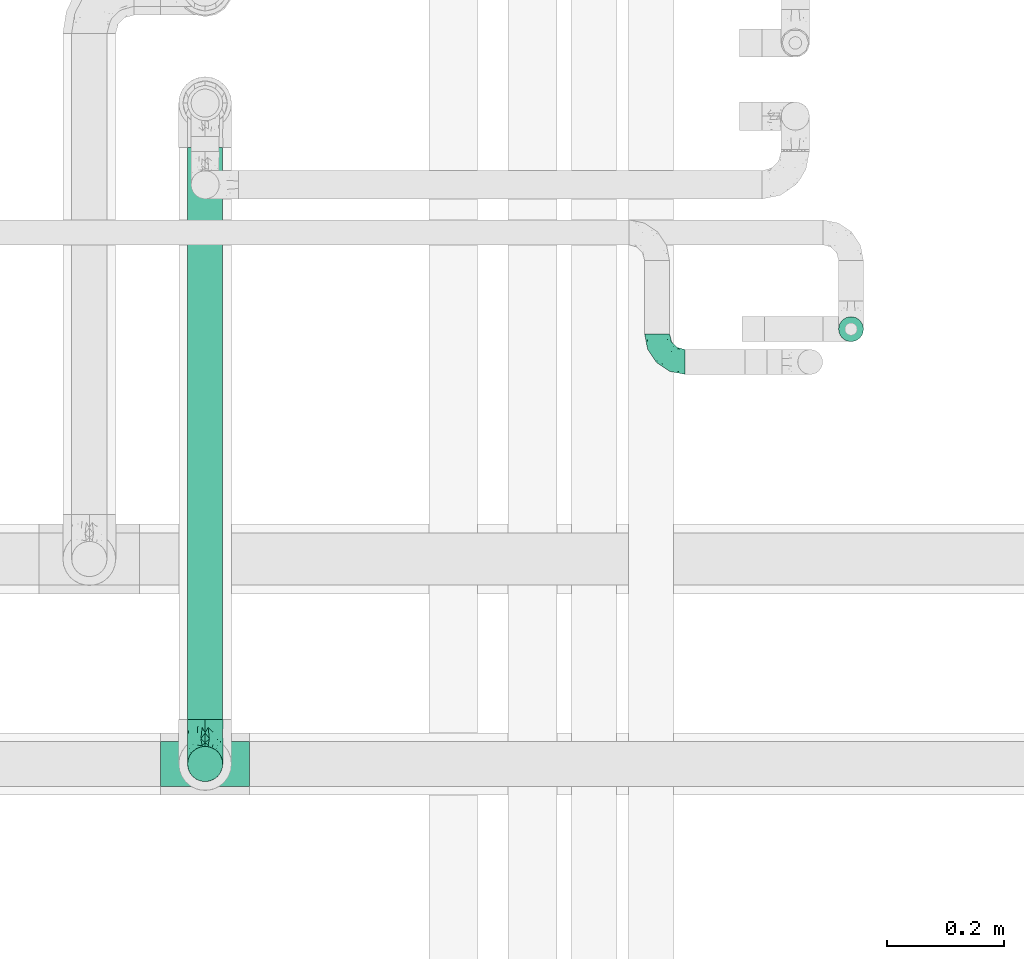
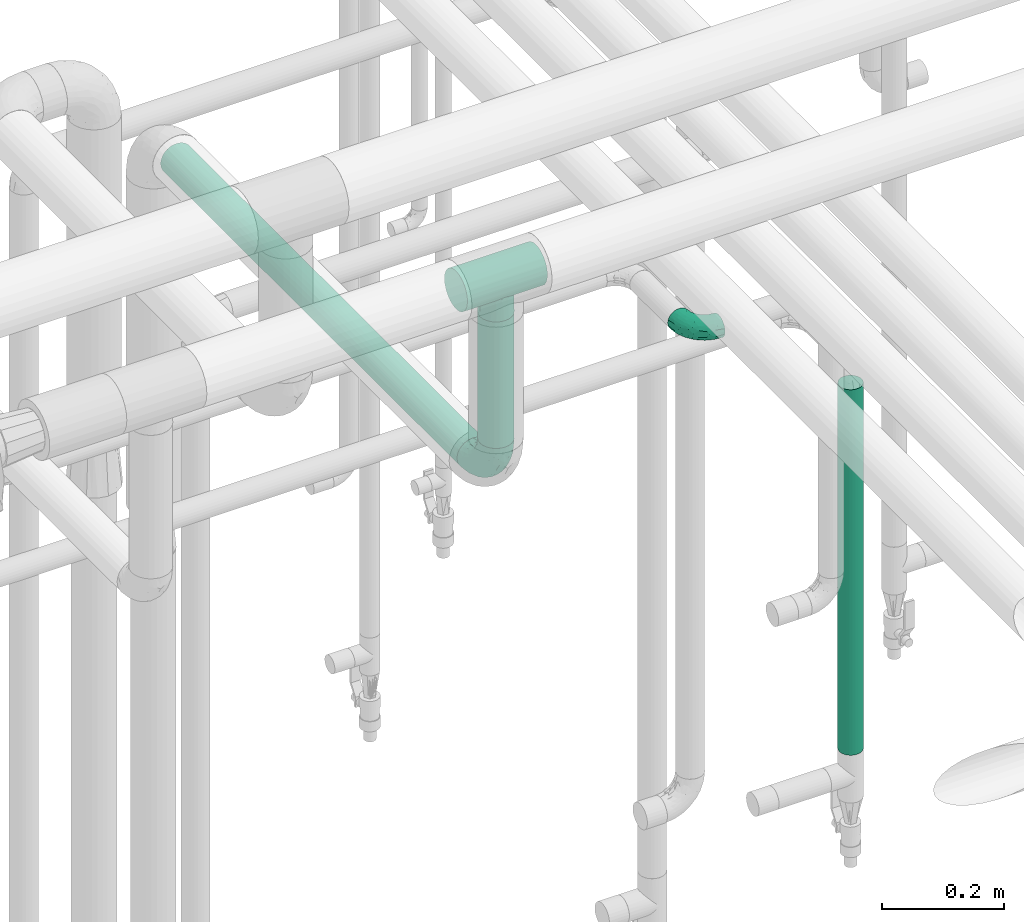
# One storey, part 574 of 827: 3 flow fittings, 3 flow segments.
"""IFC2X3 building model written with IfcOpenShell, lengths in millimetres."""

from ifc_helpers import new_model, entity, si_unit, converted_unit, derived_unit, direction, frame, origin, origin_2d_with_axis, place, context, subcontext, project, spatial, circle, extrude, faceted_brep, source, transform, mapped, material, type_object, type_shapes, element, save


model = new_model("IFC2X3")

# Units and contexts
model_context = context("Model", 3, precision=0.01, world=origin(), true_north=direction((6.12303176911189e-17, 1.0)))
body_context = subcontext(model_context, "Body", "Model", "MODEL_VIEW")
ifc_project = project(units=[si_unit("LENGTHUNIT", "METRE", prefix="MILLI"), si_unit("AREAUNIT", "SQUARE_METRE"), si_unit("VOLUMEUNIT", "CUBIC_METRE"), converted_unit("PLANEANGLEUNIT", "DEGREE", entity("IfcRatioMeasure", 0.0174532925199433), si_unit("PLANEANGLEUNIT", "RADIAN"), dimensions=[0, 0, 0, 0, 0, 0, 0]), si_unit("MASSUNIT", "GRAM", prefix="KILO"), derived_unit("MASSDENSITYUNIT", [(si_unit("MASSUNIT", "GRAM", prefix="KILO"), 1), (si_unit("LENGTHUNIT", "METRE"), -3)]), derived_unit("MOMENTOFINERTIAUNIT", [(si_unit("LENGTHUNIT", "METRE"), 4)]), si_unit("TIMEUNIT", "SECOND"), si_unit("FREQUENCYUNIT", "HERTZ"), si_unit("THERMODYNAMICTEMPERATUREUNIT", "DEGREE_CELSIUS"), derived_unit("THERMALTRANSMITTANCEUNIT", [(si_unit("MASSUNIT", "GRAM", prefix="KILO"), 1), (si_unit("THERMODYNAMICTEMPERATUREUNIT", "KELVIN"), -1), (si_unit("TIMEUNIT", "SECOND"), -3)]), derived_unit("VOLUMETRICFLOWRATEUNIT", [(si_unit("LENGTHUNIT", "METRE"), 3), (si_unit("TIMEUNIT", "SECOND"), -1)]), derived_unit("MASSFLOWRATEUNIT", [(si_unit("MASSUNIT", "GRAM", prefix="KILO"), 1), (si_unit("TIMEUNIT", "SECOND"), -1)]), derived_unit("ROTATIONALFREQUENCYUNIT", [(si_unit("TIMEUNIT", "SECOND"), -1)]), si_unit("ELECTRICCURRENTUNIT", "AMPERE"), si_unit("ELECTRICVOLTAGEUNIT", "VOLT"), si_unit("POWERUNIT", "WATT"), si_unit("FORCEUNIT", "NEWTON", prefix="KILO"), si_unit("ILLUMINANCEUNIT", "LUX"), si_unit("LUMINOUSFLUXUNIT", "LUMEN"), si_unit("LUMINOUSINTENSITYUNIT", "CANDELA"), derived_unit("USERDEFINED", [(si_unit("MASSUNIT", "GRAM", prefix="KILO"), -1), (si_unit("LENGTHUNIT", "METRE"), -2), (si_unit("TIMEUNIT", "SECOND"), 3), (si_unit("LUMINOUSFLUXUNIT", "LUMEN"), 1)]), derived_unit("LINEARVELOCITYUNIT", [(si_unit("LENGTHUNIT", "METRE"), 1), (si_unit("TIMEUNIT", "SECOND"), -1)]), si_unit("PRESSUREUNIT", "PASCAL"), derived_unit("USERDEFINED", [(si_unit("LENGTHUNIT", "METRE"), -2), (si_unit("MASSUNIT", "GRAM", prefix="KILO"), 1), (si_unit("TIMEUNIT", "SECOND"), -2)]), derived_unit("LINEARFORCEUNIT", [(si_unit("MASSUNIT", "GRAM", prefix="KILO"), 1), (si_unit("LENGTHUNIT", "METRE"), 1), (si_unit("TIMEUNIT", "SECOND"), -2), (si_unit("LENGTHUNIT", "METRE"), -1)]), derived_unit("PLANARFORCEUNIT", [(si_unit("MASSUNIT", "GRAM", prefix="KILO"), 1), (si_unit("LENGTHUNIT", "METRE"), 1), (si_unit("TIMEUNIT", "SECOND"), -2), (si_unit("LENGTHUNIT", "METRE"), -2)])], contexts=[model_context])

# Site, building, storey
site_placement = place(None, origin())
site = spatial("IfcSite", under=ifc_project, at=site_placement, CompositionType="ELEMENT")
building_placement = place(site_placement, origin())
building = spatial("IfcBuilding", under=site, at=building_placement, CompositionType="ELEMENT")
storey_placement = place(building_placement, frame((0.0, 0.0, 28200.0)))
storey = spatial("IfcBuildingStorey", under=building, at=storey_placement, Name="08", CompositionType="ELEMENT", Elevation=28200.0)

# Flow segments
pipe_segment_type = type_object("IfcPipeSegmentType", PredefinedType="NOTDEFINED")
flow_segment_1_placement = place(storey_placement, frame((19001.31, 15119.04, 1018.11)))
element("IfcFlowSegment", 1, at=flow_segment_1_placement, inside=storey, type_object=pipe_segment_type, context=body_context, shape_type="SweptSolid", body=[
    extrude(circle(Radius=21.15, at=origin_2d_with_axis()), frame((22.75, 22.75, 0.0)), (0.0, 0.0, 1.0), 733.894998191936),
])
flow_segment_2_placement = place(storey_placement, frame((17890.7, 14476.0, 2368.4)))
element("IfcFlowSegment", 2, at=flow_segment_2_placement, inside=storey, type_object=pipe_segment_type, context=body_context, shape_type="SweptSolid", body=[
    extrude(circle(Radius=30.0, at=origin_2d_with_axis()), frame((31.6, 0.0, 31.6), z_axis=(0.0, 1.0, 0.0), x_axis=(-1.0, 0.0, 0.0)), (0.0, 0.0, 1.0), 975.249133388721),
])
flow_segment_3_placement = place(storey_placement, frame((17890.7, 14368.4, 2476.0)))
element("IfcFlowSegment", 3, at=flow_segment_3_placement, inside=storey, type_object=pipe_segment_type, context=body_context, shape_type="SweptSolid", body=[
    extrude(circle(Radius=30.0, at=origin_2d_with_axis()), frame((31.6, 31.6, 0.0)), (0.0, 0.0, 1.0), 253.982896996899),
])

# Flow fittings
ifc_material = material()
pipe_fitting_type_1 = type_object("IfcPipeFittingType", Name="ADSK_1", PredefinedType="NOTDEFINED", material=ifc_material)
shared_shape_1 = source(origin(), body_context, "Body", "Brep", [
    faceted_brep([(-48.0, 10.6, -18.36), (-48.0, 5.49, -20.48), (-48.0, 0.0, -21.2), (-48.0, -5.49, -20.48), (-48.0, -10.6, -18.36), (-48.0, -14.99, -14.99), (-48.0, -18.36, -10.6), (-48.0, -20.48, -5.49), (-48.0, -21.2, 0.0), (-48.0, -20.48, 5.49), (-48.0, -18.36, 10.6), (-48.0, -14.99, 14.99), (-48.0, -10.6, 18.36), (-48.0, -5.49, 20.48), (-48.0, 0.0, 21.2), (-48.0, 5.49, 20.48), (-48.0, 10.6, 18.36), (-48.0, 14.99, 14.99), (-48.0, 18.36, 10.6), (-48.0, 20.48, 5.49), (-48.0, 21.2, 0.0), (-48.0, 20.48, -5.49), (-48.0, 18.36, -10.6), (-48.0, 14.99, -14.99), (0.0, 48.0, -21.2), (-5.49, 48.0, -20.48), (-10.6, 48.0, -18.36), (-14.99, 48.0, -14.99), (-18.36, 48.0, -10.6), (-20.48, 48.0, -5.49), (-21.2, 48.0, 0.0), (-20.48, 48.0, 5.49), (-18.36, 48.0, 10.6), (-14.99, 48.0, 14.99), (-10.6, 48.0, 18.36), (-5.49, 48.0, 20.48), (0.0, 48.0, 21.2), (5.49, 48.0, 20.48), (10.6, 48.0, 18.36), (14.99, 48.0, 14.99), (18.36, 48.0, 10.6), (20.48, 48.0, 5.49), (21.2, 48.0, 0.0), (20.48, 48.0, -5.49), (18.36, 48.0, -10.6), (14.99, 48.0, -14.99), (10.6, 48.0, -18.36), (5.49, 48.0, -20.48), (-35.25, -16.22, 12.01), (-34.76, -18.57, 0.0), (-20.87, -12.37, 10.9), (-31.49, -11.78, 15.9), (-37.0, -2.58, 20.86), (-33.89, 3.62, 21.15), (-31.81, -18.14, 6.76), (-5.78, 5.78, 17.67), (-19.42, -4.1, 17.86), (-9.6, -3.39, 13.73), (-35.44, -7.73, 19.13), (11.78, 31.49, 15.9), (-5.93, -5.46, 6.95), (-18.45, -13.78, 5.46), (-10.29, -8.43, 0.0), (-24.6, 0.55, 20.62), (-37.28, 17.94, 13.81), (-33.38, 22.85, 9.59), (-41.46, 20.06, 8.75), (-29.51, 20.45, 15.16), (-15.04, 10.79, 21.13), (-7.08, 16.98, 20.93), (-8.39, 23.51, 21.15), (-40.86, 13.03, 17.26), (-8.05, 41.26, 19.83), (-3.21, 35.97, 21.14), (8.53, 19.66, 14.74), (4.1, 19.42, 17.86), (-37.72, 22.66, 4.78), (-37.07, 8.58, 19.98), (-13.0, 5.43, 19.97), (-3.78, 13.93, 19.7), (3.02, 8.69, 13.43), (-2.27, -0.05, 10.65), (6.22, 6.99, 7.09), (-22.25, 34.6, 9.45), (18.14, 31.81, 6.76), (16.22, 35.25, 12.01), (12.37, 20.87, 10.9), (7.73, 35.44, 19.13), (-21.52, -15.93, 0.0), (2.58, 37.0, 20.86), (18.57, 34.76, 0.0), (13.78, 18.45, 5.46), (15.93, 21.52, 0.0), (-20.03, -8.54, 14.9), (-28.6, 28.6, 5.16), (-24.79, 34.6, 0.0), (-34.6, 24.79, 0.0), (-22.81, 37.41, 4.68), (-23.36, 26.33, 14.79), (-13.68, 37.05, 17.49), (-17.72, 38.12, 13.73), (-26.25, 27.3, 11.24), (-9.71, 32.34, 20.14), (-17.26, 25.6, 18.71), (-26.33, 9.99, 20.77), (-24.06, 6.05, 21.2), (-25.02, 15.46, 19.56), (-24.3, 20.72, 17.57), (-31.95, 15.23, 17.8), (-13.53, 24.7, 20.21), (-17.6, 17.6, 20.6), (-0.55, 24.6, 20.62), (-11.41, -7.48, 10.43), (0.93, -0.93, 0.0), (8.43, 10.29, 0.0), (-11.41, -7.48, -10.43), (-20.1, -8.84, -14.66), (-9.6, -3.39, -13.73), (7.73, 35.44, -19.13), (4.1, 19.42, -17.86), (-0.55, 24.6, -20.62), (-38.12, 17.72, -13.73), (-37.05, 13.68, -17.49), (-32.34, 9.71, -20.14), (-41.26, 8.05, -19.83), (-37.41, 22.81, -4.68), (-23.51, 8.39, -21.15), (-35.97, 3.21, -21.14), (-28.6, 28.6, -5.16), (-31.81, -18.14, -6.76), (-18.45, -13.78, -5.46), (-25.6, 17.26, -18.71), (-19.42, -4.1, -17.86), (-17.94, 37.28, -13.81), (-22.85, 33.38, -9.59), (-20.06, 41.46, -8.75), (-31.49, -11.78, -15.9), (-35.25, -16.22, -12.01), (8.53, 19.66, -14.74), (11.78, 31.49, -15.9), (-9.99, 26.33, -20.77), (-6.05, 24.06, -21.2), (-10.79, 15.04, -21.13), (-37.0, -2.58, -20.86), (-16.98, 7.08, -20.93), (-5.43, 13.0, -19.97), (-13.93, 3.78, -19.7), (-20.87, -12.37, -10.9), (-26.33, 23.36, -14.79), (-22.66, 37.72, -4.78), (13.78, 18.45, -5.46), (18.14, 31.81, -6.76), (-15.46, 25.02, -19.56), (-20.72, 24.3, -17.57), (16.22, 35.25, -12.01), (-13.03, 40.86, -17.26), (-8.58, 37.07, -19.98), (2.58, 37.0, -20.86), (-3.62, 33.89, -21.15), (-34.6, 22.25, -9.45), (6.22, 6.99, -7.09), (-20.45, 29.51, -15.16), (-35.44, -7.73, -19.13), (12.37, 20.87, -10.9), (-27.3, 26.25, -11.24), (-15.23, 31.95, -17.8), (-24.7, 13.53, -20.21), (-24.6, 0.55, -20.62), (-5.78, 5.78, -17.67), (-17.6, 17.6, -20.6), (3.02, 8.69, -13.43), (-5.93, -5.46, -6.95), (-2.27, -0.05, -10.65)], [[[0, 1, 2, 3, 4, 5, 6, 7, 8, 9, 10, 11, 12, 13, 14, 15, 16, 17, 18, 19, 20, 21, 22, 23]], [[24, 25, 26, 27, 28, 29, 30, 31, 32, 33, 34, 35, 36, 37, 38, 39, 40, 41, 42, 43, 44, 45, 46, 47]], [[10, 48, 11]], [[9, 8, 49]], [[48, 50, 51]], [[14, 52, 53]], [[10, 54, 48]], [[9, 54, 10]], [[55, 56, 57]], [[51, 12, 11]], [[51, 58, 12]], [[59, 39, 38]], [[60, 61, 62]], [[58, 56, 63]], [[64, 65, 66]], [[67, 65, 64]], [[68, 69, 70]], [[16, 71, 17]], [[13, 52, 14]], [[35, 72, 73]], [[14, 53, 15]], [[17, 64, 18]], [[74, 59, 75]], [[20, 19, 76]], [[66, 19, 18]], [[77, 15, 53]], [[15, 77, 16]], [[69, 78, 79]], [[80, 81, 82]], [[32, 31, 83]], [[84, 85, 86]], [[59, 87, 75]], [[61, 54, 88]], [[36, 89, 37]], [[84, 41, 40]], [[36, 35, 73]], [[90, 41, 84]], [[40, 39, 85]], [[12, 58, 13]], [[85, 84, 40]], [[91, 84, 86]], [[84, 92, 90]], [[87, 38, 37]], [[93, 56, 51]], [[65, 94, 76]], [[94, 95, 96]], [[84, 91, 92]], [[95, 97, 30]], [[98, 99, 100]], [[76, 94, 96]], [[101, 98, 83]], [[100, 99, 33]], [[102, 70, 73]], [[103, 102, 99]], [[94, 97, 95]], [[72, 99, 102]], [[72, 35, 34]], [[34, 33, 99]], [[9, 49, 54]], [[87, 59, 38]], [[104, 105, 68]], [[106, 103, 107]], [[106, 77, 104]], [[71, 64, 17]], [[108, 107, 67]], [[33, 32, 100]], [[109, 103, 110]], [[102, 109, 70]], [[89, 73, 111]], [[50, 48, 54]], [[51, 11, 48]], [[56, 58, 51]], [[88, 54, 49]], [[52, 58, 63]], [[50, 112, 93]], [[56, 55, 78]], [[39, 59, 85]], [[86, 85, 59]], [[89, 87, 37]], [[42, 41, 90]], [[111, 79, 75]], [[111, 75, 87]], [[75, 55, 80]], [[104, 77, 53]], [[71, 77, 108]], [[32, 83, 100]], [[98, 100, 83]], [[99, 98, 103]], [[106, 107, 108]], [[68, 70, 110]], [[111, 73, 70]], [[68, 110, 104]], [[68, 63, 78]], [[57, 93, 112]], [[80, 55, 57]], [[61, 50, 54]], [[80, 82, 86]], [[81, 57, 112]], [[74, 86, 59]], [[60, 113, 82]], [[82, 114, 91]], [[101, 94, 65]], [[97, 94, 83]], [[73, 89, 36]], [[87, 89, 111]], [[58, 52, 13]], [[53, 52, 63]], [[104, 53, 105]], [[106, 104, 110]], [[20, 76, 96]], [[76, 19, 66]], [[103, 106, 110]], [[77, 106, 108]], [[103, 98, 107]], [[67, 107, 98]], [[67, 98, 101]], [[108, 67, 64]], [[53, 63, 105]], [[63, 68, 105]], [[83, 31, 97]], [[30, 97, 31]], [[62, 113, 60]], [[112, 61, 60]], [[61, 88, 62]], [[86, 82, 91]], [[56, 78, 63]], [[114, 82, 113]], [[114, 92, 91]], [[79, 78, 55]], [[75, 79, 55]], [[69, 79, 111]], [[70, 69, 111]], [[78, 69, 68]], [[77, 71, 16]], [[64, 71, 108]], [[64, 66, 18]], [[76, 66, 65]], [[99, 72, 34]], [[73, 72, 102]], [[94, 101, 83]], [[67, 101, 65]], [[75, 80, 74]], [[80, 86, 74]], [[70, 109, 110]], [[102, 103, 109]], [[50, 93, 51]], [[57, 56, 93]], [[61, 112, 50]], [[81, 112, 60]], [[82, 81, 60]], [[80, 57, 81]], [[115, 116, 117]], [[118, 119, 120]], [[121, 122, 23]], [[123, 124, 122]], [[96, 125, 20]], [[123, 126, 127]], [[128, 96, 95]], [[129, 130, 88]], [[123, 122, 131]], [[116, 132, 117]], [[133, 134, 135]], [[0, 124, 1]], [[5, 136, 137]], [[138, 119, 139]], [[129, 88, 49]], [[140, 141, 142]], [[6, 5, 137]], [[46, 118, 47]], [[143, 3, 2]], [[144, 145, 146]], [[6, 129, 7]], [[129, 137, 147]], [[127, 2, 1]], [[148, 122, 121]], [[128, 125, 96]], [[134, 128, 149]], [[95, 149, 128]], [[150, 151, 92]], [[30, 29, 149]], [[152, 131, 153]], [[27, 133, 28]], [[154, 45, 44]], [[136, 5, 4]], [[27, 26, 155]], [[156, 26, 25]], [[24, 157, 158]], [[24, 47, 157]], [[22, 21, 159]], [[160, 150, 114]], [[134, 133, 161]], [[142, 144, 126]], [[46, 139, 118]], [[162, 136, 4]], [[156, 25, 158]], [[1, 124, 127]], [[115, 147, 116]], [[45, 154, 139]], [[139, 46, 45]], [[154, 163, 139]], [[162, 4, 3]], [[42, 90, 43]], [[130, 129, 147]], [[49, 7, 129]], [[43, 151, 44]], [[0, 23, 122]], [[24, 158, 25]], [[136, 162, 132]], [[135, 29, 28]], [[43, 90, 151]], [[164, 148, 159]], [[152, 156, 140]], [[155, 133, 27]], [[165, 153, 161]], [[23, 22, 121]], [[123, 131, 166]], [[123, 166, 126]], [[143, 127, 167]], [[147, 137, 136]], [[8, 7, 49]], [[129, 6, 137]], [[143, 162, 3]], [[167, 146, 132]], [[167, 132, 162]], [[132, 168, 117]], [[44, 151, 154]], [[92, 151, 90]], [[163, 154, 151]], [[119, 118, 139]], [[157, 118, 120]], [[138, 139, 163]], [[119, 168, 145]], [[140, 156, 158]], [[155, 156, 165]], [[22, 159, 121]], [[148, 121, 159]], [[122, 148, 131]], [[152, 153, 165]], [[142, 126, 169]], [[167, 127, 126]], [[142, 169, 140]], [[142, 120, 145]], [[168, 170, 117]], [[160, 171, 172]], [[115, 172, 171]], [[171, 62, 130]], [[119, 170, 168]], [[170, 163, 160]], [[150, 163, 151]], [[113, 171, 160]], [[164, 128, 134]], [[125, 128, 159]], [[127, 143, 2]], [[162, 143, 167]], [[118, 157, 47]], [[158, 157, 120]], [[140, 158, 141]], [[152, 140, 169]], [[30, 149, 95]], [[149, 29, 135]], [[131, 152, 169]], [[156, 152, 165]], [[131, 148, 153]], [[161, 153, 148]], [[161, 148, 164]], [[165, 161, 133]], [[158, 120, 141]], [[120, 142, 141]], [[159, 21, 125]], [[20, 125, 21]], [[115, 130, 147]], [[114, 113, 160]], [[62, 171, 113]], [[62, 88, 130]], [[160, 163, 150]], [[150, 92, 114]], [[119, 145, 120]], [[146, 145, 168]], [[132, 146, 168]], [[144, 146, 167]], [[126, 144, 167]], [[145, 144, 142]], [[156, 155, 26]], [[133, 155, 165]], [[133, 135, 28]], [[149, 135, 134]], [[122, 124, 0]], [[127, 124, 123]], [[128, 164, 159]], [[161, 164, 134]], [[163, 170, 138]], [[170, 119, 138]], [[131, 169, 166]], [[126, 166, 169]], [[147, 136, 116]], [[132, 116, 136]], [[172, 115, 117]], [[130, 115, 171]], [[117, 170, 172]], [[160, 172, 170]]]),
])
type_shapes(pipe_fitting_type_1, [shared_shape_1])
flow_fitting_1_placement = place(storey_placement, frame((18693.2, 15085.74, 2000.0), z_axis=(0.0, 0.0, 1.0), x_axis=(0.0, -1.0, 0.0)))
element("IfcFlowFitting", 4, at=flow_fitting_1_placement, inside=storey, type_object=pipe_fitting_type_1, material=ifc_material, Name="ADSK_1", ObjectType="ADSK_1", context=body_context, shape_type="MappedRepresentation", body=[
    mapped(shared_shape_1, transform((0.0, 0.0, 0.0), scale=1.0)),
])
pipe_fitting_type_2 = type_object("IfcPipeFittingType", Name="ADSK_1", PredefinedType="NOTDEFINED", material=ifc_material)
shared_shape_2 = source(origin(), body_context, "Body", "Brep", [
    faceted_brep([(-76.0, 15.07, -26.11), (-76.0, 7.8, -29.12), (-76.0, 0.0, -30.15), (-76.0, -7.8, -29.12), (-76.0, -15.08, -26.11), (-76.0, -21.32, -21.32), (-76.0, -26.11, -15.08), (-76.0, -29.12, -7.8), (-76.0, -30.15, 0.0), (-76.0, -29.12, 7.8), (-76.0, -26.11, 15.07), (-76.0, -21.32, 21.32), (-76.0, -15.08, 26.11), (-76.0, -7.8, 29.12), (-76.0, 0.0, 30.15), (-76.0, 7.8, 29.12), (-76.0, 15.07, 26.11), (-76.0, 21.32, 21.32), (-76.0, 26.11, 15.07), (-76.0, 29.12, 7.8), (-76.0, 30.15, 0.0), (-76.0, 29.12, -7.8), (-76.0, 26.11, -15.08), (-76.0, 21.32, -21.32), (0.0, 76.0, -30.15), (-7.8, 76.0, -29.12), (-15.07, 76.0, -26.11), (-21.32, 76.0, -21.32), (-26.11, 76.0, -15.08), (-29.12, 76.0, -7.8), (-30.15, 76.0, 0.0), (-29.12, 76.0, 7.8), (-26.11, 76.0, 15.07), (-21.32, 76.0, 21.32), (-15.07, 76.0, 26.11), (-7.8, 76.0, 29.12), (0.0, 76.0, 30.15), (7.8, 76.0, 29.12), (15.08, 76.0, 26.11), (21.32, 76.0, 21.32), (26.11, 76.0, 15.07), (29.12, 76.0, 7.8), (30.15, 76.0, 0.0), (29.12, 76.0, -7.8), (26.11, 76.0, -15.08), (21.32, 76.0, -21.32), (15.08, 76.0, -26.11), (7.8, 76.0, -29.12), (10.79, 31.43, 21.07), (4.32, 31.7, 25.72), (1.65, 15.19, 19.92), (-61.17, -27.8, 0.0), (-51.1, -25.49, 9.84), (-56.14, -10.61, 27.27), (-31.7, -4.32, 25.72), (-39.75, 1.72, 29.41), (-43.2, -24.95, 0.0), (-1.86, 1.86, 0.0), (4.49, 7.65, 5.78), (-7.82, -4.61, 5.83), (-56.21, -22.79, 17.21), (-58.98, -3.38, 29.7), (-53.96, 5.6, 30.07), (-10.86, 10.86, 25.48), (-17.2, -2.6, 20.44), (-49.15, -16.01, 22.7), (-22.18, -14.24, 7.99), (-28.4, -17.42, 0.0), (-13.61, -9.88, 0.0), (-39.0, 23.48, 27.76), (-58.76, 12.54, 28.36), (-41.61, 15.41, 29.48), (16.01, 49.15, 22.7), (-58.55, 25.93, 19.53), (-51.53, 33.5, 13.51), (-64.92, 28.76, 12.4), (-7.48, 23.14, 28.25), (-1.72, 39.75, 29.41), (-12.04, 27.88, 29.88), (-63.91, 18.81, 24.52), (-11.63, 65.16, 28.18), (-4.97, 57.02, 30.05), (9.88, 13.61, 0.0), (-62.5, 31.74, 5.02), (-45.17, 30.98, 21.2), (-21.78, 9.76, 28.58), (10.61, 56.14, 27.27), (-32.09, 54.42, 13.26), (22.79, 56.21, 17.21), (15.38, 31.17, 15.63), (25.49, 51.1, 9.84), (21.84, 36.35, 5.92), (24.95, 43.2, 0.0), (3.38, 58.98, 29.7), (-31.17, -15.38, 15.63), (-39.39, 41.78, 15.45), (-34.56, 41.13, 20.79), (-39.81, -23.25, 5.49), (27.8, 61.17, 0.0), (-31.74, 62.5, 5.02), (-53.07, 36.29, 0.0), (-42.95, 42.95, 7.29), (-36.29, 53.07, 0.0), (-19.83, 58.51, 24.79), (-25.48, 60.2, 19.41), (-14.53, 50.96, 28.57), (-13.31, 37.09, 30.07), (-26.16, 40.06, 26.4), (-32.43, -10.35, 21.9), (17.42, 28.4, 0.0), (14.24, 22.18, 7.99), (-38.67, 9.72, 30.15), (-24.66, 17.36, 30.09), (-37.08, 31.49, 24.99), (-49.27, 22.83, 25.24), (-20.8, 38.81, 28.63), (-27.58, 27.58, 29.2), (-36.07, -20.23, 10.71), (-15.19, -6.16, 14.9), (6.6, 15.4, 14.49), (-2.51, 2.51, 11.35), (-65.16, 11.63, -28.18), (-49.15, -16.01, -22.7), (-57.02, 4.97, -30.05), (-25.93, 58.55, -19.53), (-33.5, 51.53, -13.51), (-28.76, 64.92, -12.4), (-60.2, 25.48, -19.41), (-58.51, 19.83, -24.79), (4.61, 7.82, -5.83), (-7.65, -4.49, -5.78), (-2.51, 2.51, -11.35), (-62.5, 31.74, -5.02), (-50.96, 14.53, -28.57), (-37.09, 13.31, -30.07), (-42.95, 42.95, -7.29), (25.49, 51.1, -9.84), (22.79, 56.21, -17.21), (-40.06, 26.16, -26.4), (3.38, 58.98, -29.7), (-5.6, 53.96, -30.07), (-27.88, 12.04, -29.88), (-9.76, 21.78, -28.58), (-23.14, 7.48, -28.25), (-51.1, -25.49, -9.84), (15.38, 31.17, -15.63), (16.01, 49.15, -22.7), (-23.48, 39.0, -27.76), (-12.54, 58.76, -28.36), (-15.41, 41.61, -29.48), (-56.21, -22.79, -17.21), (-9.72, 38.67, -30.15), (-17.36, 24.66, -30.09), (-22.18, -14.24, -7.99), (-41.13, 34.56, -20.79), (-31.74, 62.5, -5.02), (-58.98, -3.38, -29.7), (-31.17, -15.38, -15.63), (-56.14, -10.61, -27.27), (14.24, 22.18, -7.99), (23.25, 39.81, -5.49), (-31.49, 37.08, -24.99), (-15.19, -6.16, -14.9), (1.65, 15.19, -19.92), (-18.81, 63.91, -24.52), (-32.59, -11.62, -20.84), (-31.7, -4.32, -25.72), (-17.2, -2.6, -20.44), (-39.75, 1.72, -29.41), (-54.42, 32.09, -13.26), (-30.98, 45.17, -21.2), (10.61, 56.14, -27.27), (10.23, 31.31, -21.52), (4.32, 31.7, -25.72), (-41.78, 39.39, -15.45), (-1.72, 39.75, -29.41), (-36.35, -21.84, -5.92), (-22.83, 49.27, -25.24), (-38.81, 20.8, -28.63), (-27.58, 27.58, -29.2), (-10.86, 10.86, -25.48), (20.23, 36.07, -10.71), (6.6, 15.4, -14.49)], [[[0, 1, 2, 3, 4, 5, 6, 7, 8, 9, 10, 11, 12, 13, 14, 15, 16, 17, 18, 19, 20, 21, 22, 23]], [[24, 25, 26, 27, 28, 29, 30, 31, 32, 33, 34, 35, 36, 37, 38, 39, 40, 41, 42, 43, 44, 45, 46, 47]], [[48, 49, 50]], [[51, 52, 9]], [[53, 54, 55]], [[9, 52, 10]], [[56, 52, 51]], [[57, 58, 59]], [[11, 10, 60]], [[14, 61, 62]], [[63, 54, 64]], [[65, 12, 11]], [[65, 53, 12]], [[66, 67, 68]], [[69, 70, 71]], [[72, 39, 38]], [[73, 74, 75]], [[15, 70, 16]], [[76, 77, 78]], [[16, 79, 17]], [[13, 61, 14]], [[35, 80, 81]], [[14, 62, 15]], [[17, 73, 18]], [[57, 82, 58]], [[20, 19, 83]], [[75, 19, 18]], [[70, 15, 62]], [[73, 84, 74]], [[78, 85, 76]], [[38, 86, 72]], [[32, 31, 87]], [[88, 89, 90]], [[91, 92, 90]], [[72, 86, 49]], [[36, 93, 37]], [[75, 83, 19]], [[36, 35, 81]], [[60, 94, 65]], [[40, 90, 41]], [[95, 96, 87]], [[88, 90, 40]], [[66, 97, 67]], [[90, 98, 41]], [[40, 39, 88]], [[99, 31, 30]], [[20, 83, 100]], [[101, 102, 100]], [[52, 60, 10]], [[102, 99, 30]], [[96, 103, 104]], [[83, 101, 100]], [[12, 53, 13]], [[104, 103, 33]], [[105, 106, 81]], [[107, 105, 103]], [[64, 54, 108]], [[80, 103, 105]], [[80, 35, 34]], [[34, 33, 103]], [[86, 38, 37]], [[109, 110, 82]], [[71, 111, 112]], [[69, 107, 113]], [[79, 73, 17]], [[114, 113, 84]], [[33, 32, 104]], [[115, 107, 116]], [[105, 115, 106]], [[93, 81, 77]], [[54, 53, 65]], [[61, 53, 55]], [[108, 94, 64]], [[54, 63, 85]], [[93, 86, 37]], [[77, 76, 49]], [[77, 49, 86]], [[49, 63, 50]], [[60, 52, 117]], [[65, 11, 60]], [[39, 72, 88]], [[89, 88, 72]], [[71, 70, 62]], [[79, 70, 114]], [[103, 96, 107]], [[69, 113, 114]], [[112, 106, 116]], [[77, 81, 106]], [[112, 116, 71]], [[112, 55, 85]], [[64, 50, 63]], [[57, 59, 68]], [[32, 87, 104]], [[96, 104, 87]], [[94, 118, 64]], [[50, 119, 89]], [[50, 64, 118]], [[50, 89, 48]], [[81, 93, 36]], [[86, 93, 77]], [[53, 61, 13]], [[62, 61, 55]], [[71, 62, 111]], [[69, 71, 116]], [[95, 101, 74]], [[99, 101, 87]], [[118, 66, 59]], [[117, 97, 66]], [[117, 66, 94]], [[91, 89, 110]], [[91, 110, 109]], [[110, 89, 119]], [[9, 8, 51]], [[98, 90, 92]], [[98, 42, 41]], [[101, 83, 74]], [[101, 99, 102]], [[87, 31, 99]], [[62, 55, 111]], [[55, 112, 111]], [[107, 69, 116]], [[70, 69, 114]], [[107, 96, 113]], [[84, 113, 96]], [[84, 96, 95]], [[114, 84, 73]], [[70, 79, 16]], [[73, 79, 114]], [[54, 85, 55]], [[76, 85, 63]], [[49, 76, 63]], [[77, 106, 78]], [[106, 112, 78]], [[85, 78, 112]], [[73, 75, 18]], [[83, 75, 74]], [[103, 80, 34]], [[81, 80, 105]], [[101, 95, 87]], [[84, 95, 74]], [[106, 115, 116]], [[105, 107, 115]], [[120, 59, 58]], [[82, 110, 58]], [[119, 58, 110]], [[118, 59, 120]], [[66, 68, 59]], [[54, 65, 108]], [[94, 108, 65]], [[66, 118, 94]], [[50, 118, 120]], [[50, 120, 119]], [[119, 120, 58]], [[89, 72, 48]], [[49, 48, 72]], [[60, 117, 94]], [[117, 52, 97]], [[52, 56, 97]], [[67, 97, 56]], [[92, 91, 109]], [[89, 91, 90]], [[121, 1, 0]], [[122, 5, 4]], [[2, 1, 123]], [[124, 125, 126]], [[127, 128, 23]], [[129, 130, 131]], [[100, 132, 20]], [[133, 134, 123]], [[135, 100, 102]], [[136, 137, 44]], [[133, 128, 138]], [[24, 139, 140]], [[141, 142, 143]], [[121, 128, 133]], [[6, 144, 7]], [[137, 145, 146]], [[144, 51, 7]], [[147, 148, 149]], [[144, 6, 150]], [[149, 151, 152]], [[153, 68, 67]], [[154, 128, 127]], [[30, 155, 102]], [[43, 42, 98]], [[156, 3, 2]], [[157, 144, 150]], [[158, 4, 3]], [[24, 140, 25]], [[155, 135, 102]], [[159, 160, 109]], [[30, 29, 155]], [[147, 138, 161]], [[27, 124, 28]], [[57, 129, 82]], [[162, 163, 131]], [[27, 26, 164]], [[148, 26, 25]], [[165, 166, 167]], [[24, 47, 139]], [[143, 168, 141]], [[22, 21, 169]], [[125, 124, 170]], [[148, 25, 140]], [[46, 146, 171]], [[158, 122, 4]], [[0, 23, 128]], [[1, 121, 123]], [[109, 82, 159]], [[45, 44, 137]], [[146, 46, 45]], [[136, 43, 98]], [[132, 21, 20]], [[136, 98, 92]], [[172, 173, 146]], [[46, 171, 47]], [[43, 136, 44]], [[174, 154, 169]], [[171, 173, 175]], [[6, 5, 150]], [[126, 29, 28]], [[176, 56, 144]], [[122, 158, 166]], [[164, 124, 27]], [[177, 161, 170]], [[23, 22, 127]], [[178, 138, 179]], [[133, 178, 134]], [[156, 123, 168]], [[156, 158, 3]], [[168, 143, 166]], [[168, 166, 158]], [[166, 180, 167]], [[173, 171, 146]], [[139, 171, 175]], [[172, 145, 163]], [[173, 180, 142]], [[5, 122, 150]], [[157, 150, 122]], [[137, 136, 181]], [[146, 45, 137]], [[149, 148, 140]], [[164, 148, 177]], [[128, 154, 138]], [[147, 161, 177]], [[152, 134, 179]], [[168, 123, 134]], [[152, 179, 149]], [[152, 175, 142]], [[57, 130, 129]], [[157, 165, 167]], [[22, 169, 127]], [[154, 127, 169]], [[163, 167, 180]], [[162, 157, 167]], [[173, 163, 180]], [[182, 163, 145]], [[123, 156, 2]], [[158, 156, 168]], [[171, 139, 47]], [[140, 139, 175]], [[149, 140, 151]], [[147, 149, 179]], [[174, 135, 125]], [[132, 135, 169]], [[176, 157, 153]], [[176, 153, 67]], [[153, 157, 162]], [[182, 159, 129]], [[181, 160, 159]], [[181, 159, 145]], [[51, 144, 56]], [[51, 8, 7]], [[135, 132, 100]], [[169, 21, 132]], [[126, 155, 29]], [[135, 155, 125]], [[140, 175, 151]], [[175, 152, 151]], [[138, 147, 179]], [[148, 147, 177]], [[138, 154, 161]], [[170, 161, 154]], [[170, 154, 174]], [[177, 170, 124]], [[148, 164, 26]], [[124, 164, 177]], [[173, 142, 175]], [[143, 142, 180]], [[166, 143, 180]], [[168, 134, 141]], [[134, 152, 141]], [[142, 141, 152]], [[124, 126, 28]], [[155, 126, 125]], [[128, 121, 0]], [[123, 121, 133]], [[135, 174, 169]], [[170, 174, 125]], [[134, 178, 179]], [[133, 138, 178]], [[130, 153, 162]], [[68, 153, 130]], [[57, 68, 130]], [[182, 129, 131]], [[159, 82, 129]], [[157, 122, 165]], [[166, 165, 122]], [[163, 162, 167]], [[162, 131, 130]], [[145, 172, 146]], [[163, 173, 172]], [[159, 182, 145]], [[131, 163, 182]], [[56, 176, 67]], [[157, 176, 144]], [[137, 181, 145]], [[181, 136, 160]], [[136, 92, 160]], [[109, 160, 92]]]),
])
type_shapes(pipe_fitting_type_2, [shared_shape_2])
flow_fitting_2_placement = place(storey_placement, frame((17922.29, 14400.0, 2400.0), z_axis=(1.0, 0.0, 0.0), x_axis=(0.0, 0.0, -1.0)))
element("IfcFlowFitting", 5, at=flow_fitting_2_placement, inside=storey, type_object=pipe_fitting_type_2, material=ifc_material, Name="ADSK_1", ObjectType="ADSK_1", context=body_context, shape_type="MappedRepresentation", body=[
    mapped(shared_shape_2, transform((0.0, 0.0, 0.0), scale=1.0)),
])
pipe_fitting_type_3 = type_object("IfcPipeFittingType", Name="ADSK_1", PredefinedType="NOTDEFINED", material=ifc_material)
shared_shape_3 = source(origin(), body_context, "Body", "Brep", [
    faceted_brep([(-76.0, 9.85, -36.75), (-76.0, 0.0, -38.05), (-76.0, -9.85, -36.75), (-76.0, -19.03, -32.95), (-76.0, -26.91, -26.91), (-76.0, -32.95, -19.03), (-76.0, -36.75, -9.85), (-76.0, -38.05, 0.0), (-76.0, -36.75, 9.85), (-76.0, -32.95, 19.02), (-76.0, -26.91, 26.91), (-76.0, -19.03, 32.95), (-76.0, -9.85, 36.75), (-76.0, 0.0, 38.05), (-76.0, 9.85, 36.75), (-76.0, 19.02, 32.95), (-76.0, 26.91, 26.91), (-76.0, 32.95, 19.02), (-76.0, 36.75, 9.85), (-76.0, 38.05, 0.0), (-76.0, 36.75, -9.85), (-76.0, 32.95, -19.03), (-76.0, 26.91, -26.91), (-76.0, 19.02, -32.95), (76.0, 26.91, -26.91), (76.0, 32.95, -19.03), (76.0, 36.75, -9.85), (76.0, 38.05, 0.0), (76.0, 36.75, 9.85), (76.0, 32.95, 19.02), (76.0, 26.91, 26.91), (76.0, 19.02, 32.95), (76.0, 9.85, 36.75), (76.0, 0.0, 38.05), (76.0, -9.85, 36.75), (76.0, -19.03, 32.95), (76.0, -26.91, 26.91), (76.0, -32.95, 19.02), (76.0, -36.75, 9.85), (76.0, -38.05, 0.0), (76.0, -36.75, -9.85), (76.0, -32.95, -19.03), (76.0, -26.91, -26.91), (76.0, -19.03, -32.95), (76.0, -9.85, -36.75), (76.0, 0.0, -38.05), (76.0, 9.85, -36.75), (76.0, 19.02, -32.95), (30.15, -38.05, 0.0), (-30.15, -38.05, 0.0), (28.17, -36.5, 10.76), (29.16, -37.27, 5.38), (22.87, -32.58, 19.65), (15.21, -27.75, 26.03), (5.49, -23.85, 29.65), (-29.16, -37.27, 5.38), (-28.17, -36.5, 10.75), (-15.21, -27.75, 26.03), (-5.5, -23.85, 29.64), (-22.87, -32.59, 19.65), (0.0, -23.85, 29.65), (5.49, -23.85, -29.65), (22.87, -32.58, -19.65), (15.21, -27.75, -26.03), (28.17, -36.5, -10.76), (29.16, -37.27, -5.38), (-5.5, -23.85, -29.64), (-15.21, -27.75, -26.03), (-22.87, -32.59, -19.65), (-28.17, -36.5, -10.75), (-29.16, -37.27, -5.38), (0.0, -23.85, -29.65), (0.0, -70.0, -30.15), (7.8, -70.0, -29.12), (15.08, -70.0, -26.11), (21.32, -70.0, -21.32), (26.11, -70.0, -15.08), (29.12, -70.0, -7.8), (30.15, -70.0, 0.0), (29.12, -70.0, 7.8), (26.11, -70.0, 15.07), (21.32, -70.0, 21.32), (15.08, -70.0, 26.11), (7.8, -70.0, 29.12), (0.0, -70.0, 30.15), (-7.8, -70.0, 29.12), (-15.07, -70.0, 26.11), (-21.32, -70.0, 21.32), (-26.11, -70.0, 15.07), (-29.12, -70.0, 7.8), (-30.15, -70.0, 0.0), (-29.12, -70.0, -7.8), (-26.11, -70.0, -15.08), (-21.32, -70.0, -21.32), (-15.07, -70.0, -26.11), (-7.8, -70.0, -29.12)], [[[0, 1, 2, 3, 4, 5, 6, 7, 8, 9, 10, 11, 12, 13, 14, 15, 16, 17, 18, 19, 20, 21, 22, 23]], [[24, 25, 26, 27, 28, 29, 30, 31, 32, 33, 34, 35, 36, 37, 38, 39, 40, 41, 42, 43, 44, 45, 46, 47]], [[39, 38, 48]], [[8, 7, 49]], [[38, 50, 51, 48]], [[38, 37, 50]], [[37, 36, 52]], [[53, 52, 36]], [[54, 53, 36]], [[36, 35, 54]], [[37, 52, 50]], [[8, 49, 55, 56]], [[56, 9, 8]], [[57, 58, 10]], [[9, 59, 10]], [[59, 9, 56]], [[10, 59, 57]], [[58, 11, 10]], [[11, 58, 60, 54]], [[13, 12, 34, 33]], [[12, 11, 35, 34]], [[14, 13, 33, 32]], [[29, 28, 18, 17]], [[16, 15, 31, 30]], [[17, 16, 30, 29]], [[32, 31, 15, 14]], [[19, 18, 28, 27]], [[35, 11, 54]], [[26, 25, 21, 20]], [[25, 24, 22, 21]], [[27, 26, 20, 19]], [[45, 44, 2, 1]], [[0, 23, 47, 46]], [[1, 0, 46, 45]], [[24, 47, 23, 22]], [[3, 2, 44, 43]], [[43, 61, 3]], [[42, 62, 63]], [[62, 42, 41]], [[63, 61, 42]], [[42, 61, 43]], [[40, 39, 48]], [[6, 49, 7]], [[40, 64, 41]], [[40, 48, 65, 64]], [[41, 64, 62]], [[66, 67, 4]], [[4, 68, 5]], [[68, 4, 67]], [[66, 4, 3]], [[6, 69, 70, 49]], [[69, 6, 5]], [[69, 5, 68]], [[3, 61, 71, 66]], [[72, 73, 74, 75, 76, 77, 78, 79, 80, 81, 82, 83, 84, 85, 86, 87, 88, 89, 90, 91, 92, 93, 94, 95]], [[51, 78, 48]], [[57, 87, 86]], [[87, 59, 88]], [[57, 86, 85]], [[55, 49, 90]], [[90, 89, 55]], [[89, 88, 56]], [[89, 56, 55]], [[59, 56, 88]], [[87, 57, 59]], [[51, 50, 79]], [[85, 58, 57]], [[84, 54, 60, 58]], [[53, 83, 82]], [[81, 53, 82]], [[50, 80, 79]], [[81, 80, 52]], [[54, 84, 83]], [[83, 53, 54]], [[84, 58, 85]], [[53, 81, 52]], [[52, 80, 50]], [[78, 51, 79]], [[77, 65, 78]], [[72, 61, 73]], [[70, 90, 49]], [[77, 64, 65]], [[77, 76, 64]], [[75, 62, 76]], [[65, 48, 78]], [[64, 76, 62]], [[74, 73, 63]], [[63, 62, 75]], [[63, 73, 61]], [[63, 75, 74]], [[72, 66, 71, 61]], [[67, 95, 94]], [[93, 67, 94]], [[69, 92, 91]], [[93, 92, 68]], [[66, 72, 95]], [[95, 67, 66]], [[67, 93, 68]], [[68, 92, 69]], [[90, 70, 91]], [[70, 69, 91]]]),
])
type_shapes(pipe_fitting_type_3, [shared_shape_3])
flow_fitting_3_placement = place(storey_placement, frame((17922.29, 14400.0, 2799.98), z_axis=(0.0, -1.0, 0.0), x_axis=(1.0, 0.0, 0.0)))
element("IfcFlowFitting", 6, at=flow_fitting_3_placement, inside=storey, type_object=pipe_fitting_type_3, material=ifc_material, Name="ADSK_1", ObjectType="ADSK_1", context=body_context, shape_type="MappedRepresentation", body=[
    mapped(shared_shape_3, transform((0.0, 0.0, 0.0), scale=1.0)),
])

save(model, "model.ifc")
